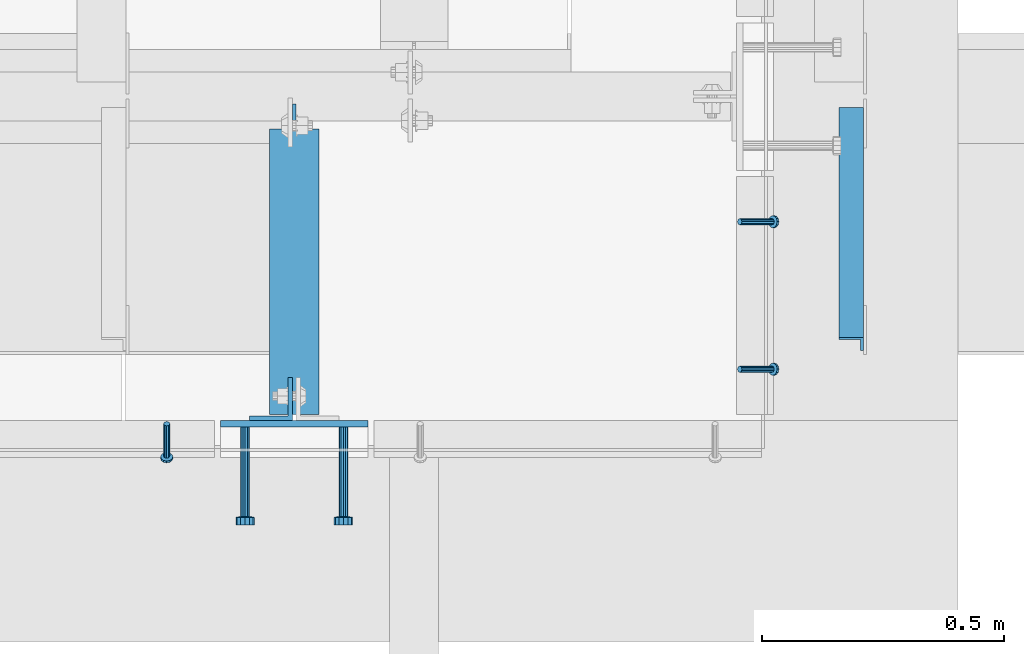
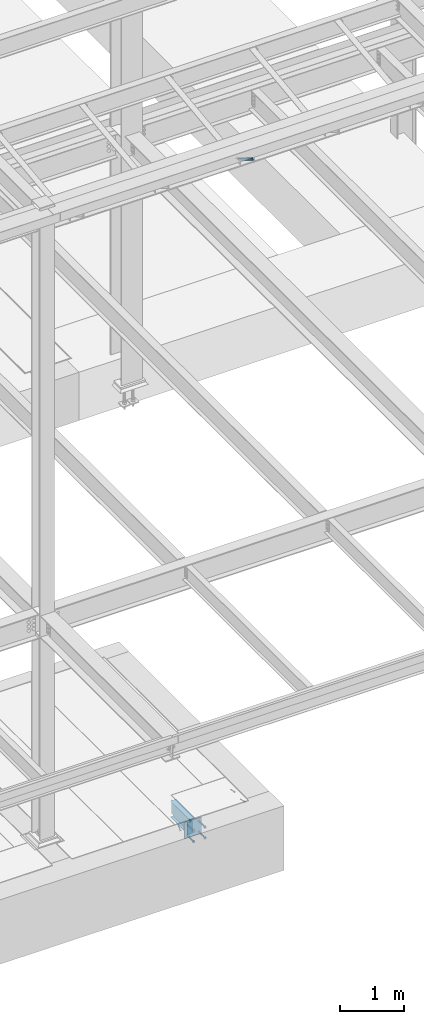
# One storey, part 2053 of 3843: 7 beams, 4 members, 5 elements without a shape of their own.
"""IFC2X3 building model written with IfcOpenShell, lengths in millimetres."""

import ifcopenshell
import ifcopenshell.guid

model = None  # the IFC model being written
_history = None  # IfcOwnerHistory: only IFC2X3 demands one
_inside = {}  # id of a spatial element -> (the spatial element, [elements in it])
_under = {}  # id of a project, library or spatial element -> (it, [spatial elements below it])
_declared = {}  # id of a project -> (the project, [libraries it declares])
_typed = {}  # id of a type object -> (the type object, [elements of that type])
_made_of = {}  # id of a material, layer set ... -> (it, [elements and type objects made of it])


def new_model(schema):
    """Start an empty IFC model of exactly this schema.

    Asked for "IFC4X3", IfcOpenShell would pick the latest addendum, in which some entities
    have other attributes; the version numbers below select the first issue.
    IFC2X3 requires an IfcOwnerHistory on every rooted entity: one is made here for all.
    """
    global model, _history
    if schema == "IFC4X3":
        model = ifcopenshell.file(schema_version=(4, 3, 0, 0))
    else:
        model = ifcopenshell.file(schema=schema)
    _inside.clear()
    _under.clear()
    _declared.clear()
    _typed.clear()
    _made_of.clear()
    _history = None
    if model.schema == "IFC2X3":
        org = make("IfcOrganization", Name="unknown")
        user = make(
            "IfcPersonAndOrganization",
            ThePerson=make("IfcPerson", FamilyName="unknown"),
            TheOrganization=org,
        )
        app = make(
            "IfcApplication",
            ApplicationDeveloper=org,
            Version="unknown",
            ApplicationFullName="unknown",
            ApplicationIdentifier="unknown",
        )
        _history = make(
            "IfcOwnerHistory",
            OwningUser=user,
            OwningApplication=app,
            ChangeAction="ADDED",
            CreationDate=0,
        )
    return model


def make(cls, **values):
    """One entity of the class cls with the attributes given. An attribute that is None is left unset."""
    return model.create_entity(
        cls, **{name: value for name, value in values.items() if value is not None}
    )


def rooted(cls, **values):
    """An entity with a GlobalId (a new one), such as an element, a storey or a relation."""
    return make(cls, GlobalId=ifcopenshell.guid.new(), OwnerHistory=_history, **values)


def si_unit(unit_type, name, prefix=None):
    """IfcSIUnit, for example si_unit("LENGTHUNIT", "METRE", prefix="MILLI")."""
    return make("IfcSIUnit", UnitType=unit_type, Prefix=prefix, Name=name)


def assignment(units):
    """IfcUnitAssignment: the units of a project."""
    return None if units is None else make("IfcUnitAssignment", Units=units)


def point(xyz):
    """IfcCartesianPoint."""
    return None if xyz is None else make("IfcCartesianPoint", Coordinates=xyz)


def direction(xyz):
    """IfcDirection."""
    return None if xyz is None else make("IfcDirection", DirectionRatios=xyz)


def frame(location, z_axis=None, x_axis=None):
    """IfcAxis2Placement3D, a coordinate frame: its origin and axes. An axis left out is left unset."""
    return make(
        "IfcAxis2Placement3D",
        Location=point(location),
        Axis=direction(z_axis),
        RefDirection=direction(x_axis),
    )


def origin_with_axes():
    """The frame at (0, 0, 0) with the z axis (0, 0, 1) and the x axis (1, 0, 0) written out."""
    return frame((0.0, 0.0, 0.0), z_axis=(0.0, 0.0, 1.0), x_axis=(1.0, 0.0, 0.0))


def place(relative_to, where):
    """IfcLocalPlacement: puts the frame where relative to a parent placement (None: the world)."""
    return make(
        "IfcLocalPlacement", PlacementRelTo=relative_to, RelativePlacement=where
    )


def context(
    kind, dimensions, precision=None, world=None, true_north=None, identifier=None
):
    """IfcGeometricRepresentationContext, for example the 3D "Model" context."""
    return make(
        "IfcGeometricRepresentationContext",
        ContextIdentifier=identifier,
        ContextType=kind,
        CoordinateSpaceDimension=dimensions,
        Precision=precision,
        WorldCoordinateSystem=world,
        TrueNorth=true_north,
    )


def subcontext(parent, identifier, kind, view, scale=None):
    """IfcGeometricRepresentationSubContext, for example "Body" below "Model"."""
    return make(
        "IfcGeometricRepresentationSubContext",
        ContextIdentifier=identifier,
        ContextType=kind,
        ParentContext=parent,
        TargetScale=scale,
        TargetView=view,
    )


def project(units=None, contexts=None):
    """IfcProject with its units and contexts."""
    return rooted(
        "IfcProject",
        Name="project",
        RepresentationContexts=contexts,
        UnitsInContext=assignment(units),
    )


def spatial(cls, under=None, at=None, **own):
    """A site, building, storey or space (cls), placed at a placement, below another one or the project."""
    s = rooted(cls, ObjectPlacement=at, **own)
    if under is not None:
        _under.setdefault(under.id(), (under, []))[1].append(s)
    return s


def faces_of(points, faces, orient=None, outer=None):
    """IfcFace entities. A face is a list of loops; a loop is a list of indices into points, from 0.

    orient and outer hold one flag for each loop. By default every Orientation is true, the
    first loop of a face is its IfcFaceOuterBound and the others are IfcFaceBound.
    """
    made = []
    for i, loops in enumerate(faces):
        bounds = []
        for j, loop in enumerate(loops):
            is_outer = j == 0 if outer is None else outer[i][j]
            bounds.append(
                make(
                    "IfcFaceOuterBound" if is_outer else "IfcFaceBound",
                    Bound=make("IfcPolyLoop", Polygon=[points[k] for k in loop]),
                    Orientation=True if orient is None else orient[i][j],
                )
            )
        made.append(make("IfcFace", Bounds=bounds))
    return made


def faceted_brep(points, faces, orient=None, outer=None, voids=None):
    """IfcFacetedBrep: a solid bounded by flat faces; with voids (closed shells), ...WithVoids."""
    shared = [point(p) for p in points]
    hull = make("IfcClosedShell", CfsFaces=faces_of(shared, faces, orient, outer))
    if voids is None:
        return make("IfcFacetedBrep", Outer=hull)
    return make(
        "IfcFacetedBrepWithVoids",
        Outer=hull,
        Voids=[
            make(cls, CfsFaces=faces_of(shared, fs, o, b)) for cls, fs, o, b in voids
        ],
    )


def shape(context_of_items, identifier, shape_type, items):
    """IfcShapeRepresentation: the items that make up one representation, for example the "Body"."""
    return make(
        "IfcShapeRepresentation",
        ContextOfItems=context_of_items,
        RepresentationIdentifier=identifier,
        RepresentationType=shape_type,
        Items=items,
    )


def material(Name=None, Category=None):
    """IfcMaterial."""
    return make("IfcMaterial", Name=Name, Category=Category)


def made_of(thing, what):
    """Note that an element or type object is made of a material, layer set ...; save() writes the relation."""
    if what is not None:
        _made_of.setdefault(what.id(), (what, []))[1].append(thing)
    return thing


def type_object(cls, material=None, **own):
    """A type object (cls), such as IfcWallType, which elements share."""
    return made_of(rooted(cls, **own), material)


def element(
    cls,
    number,
    at=None,
    inside=None,
    cuts=None,
    type_object=None,
    material=None,
    context=None,
    identifier="Body",
    shape_type=None,
    held_by="IfcProductDefinitionShape",
    body=None,
    shapes=None,
    **own,
):
    """One element of the class cls, such as IfcWall. Its Tag is "e" and its number.

    at: its placement. inside: the storey or other place that contains it. cuts: it is an
    opening in that element (IfcRelVoidsElement). A single representation is given by context,
    identifier, shape_type and body (its items); several are given by shapes. held_by: the class
    of the entity that holds the representations. save() writes the other relations.
    """
    e = rooted(cls, Tag="e%d" % number, ObjectPlacement=at, **own)
    if body is not None:
        shapes = [shape(context, identifier, shape_type, body)]
    if shapes is not None:
        e.Representation = make(held_by, Representations=shapes)
    if inside is not None:
        _inside.setdefault(inside.id(), (inside, []))[1].append(e)
    if cuts is not None:
        rooted(
            "IfcRelVoidsElement", RelatingBuildingElement=cuts, RelatedOpeningElement=e
        )
    if type_object is not None:
        _typed.setdefault(type_object.id(), (type_object, []))[1].append(e)
    return made_of(e, material)


def aggregate(whole, parts):
    """IfcRelAggregates: a whole, such as a stair, and the parts it consists of."""
    return rooted("IfcRelAggregates", RelatingObject=whole, RelatedObjects=parts)


def save(model, path):
    """Write the relations noted so far, then the file.

    IfcRelAggregates (storeys below a building ...), IfcRelContainedInSpatialStructure (elements
    in a storey), IfcRelDefinesByType, IfcRelAssociatesMaterial and IfcRelDeclares: one each for
    every whole, place, type object, material and project.
    """
    for whole, parts in _under.values():
        aggregate(whole, parts)
    for where, things in _inside.values():
        rooted(
            "IfcRelContainedInSpatialStructure",
            RelatedElements=things,
            RelatingStructure=where,
        )
    for kind, things in _typed.values():
        rooted("IfcRelDefinesByType", RelatedObjects=things, RelatingType=kind)
    for what, things in _made_of.values():
        rooted("IfcRelAssociatesMaterial", RelatedObjects=things, RelatingMaterial=what)
    for by, libraries in _declared.values():
        rooted("IfcRelDeclares", RelatingContext=by, RelatedDefinitions=libraries)
    model.write(path)


model = new_model("IFC2X3")

# Units and contexts
model_context = context("Model", 3, precision=1e-05, world=origin_with_axes())
body_context = subcontext(model_context, "Body", "Model", "MODEL_VIEW")
ifc_project = project(units=[si_unit("LENGTHUNIT", "METRE", prefix="MILLI"), si_unit("AREAUNIT", "SQUARE_METRE"), si_unit("VOLUMEUNIT", "CUBIC_METRE"), si_unit("MASSUNIT", "GRAM", prefix="KILO"), si_unit("TIMEUNIT", "SECOND"), si_unit("PLANEANGLEUNIT", "RADIAN"), si_unit("SOLIDANGLEUNIT", "STERADIAN"), si_unit("THERMODYNAMICTEMPERATUREUNIT", "DEGREE_CELSIUS"), si_unit("LUMINOUSINTENSITYUNIT", "LUMEN")], contexts=[model_context])

# Site, building, storey
site_placement = place(None, origin_with_axes())
site = spatial("IfcSite", under=ifc_project, at=site_placement, CompositionType="ELEMENT")
building_placement = place(site_placement, origin_with_axes())
building = spatial("IfcBuilding", under=site, at=building_placement, Name="Undefined", CompositionType="ELEMENT")
storey_placement = place(building_placement, origin_with_axes())
storey = spatial("IfcBuildingStorey", under=building, at=storey_placement, Name="Undefined", CompositionType="ELEMENT", Elevation=0.0)

# Assembly, members
assembly_1_placement = place(storey_placement, origin_with_axes())
assembly_1 = element("IfcElementAssembly", 1, at=assembly_1_placement, inside=storey, Name="ANGLE", AssemblyPlace="NOTDEFINED", PredefinedType="RIGID_FRAME")
ifc_material_1 = material(Name="STEEL/A108")
member_type_1 = type_object("IfcMemberType", PredefinedType="NOTDEFINED")
member_1_placement = place(assembly_1_placement, frame((65849.5000291437, 14739.9375896267, 30422.8500045777), z_axis=(0.0, 1.0, 0.0), x_axis=(0.707106781186548, 0.0, -0.707106781186548)))
member_1 = element("IfcMember", 2, at=member_1_placement, type_object=member_type_1, material=ifc_material_1, Name="HEADED STUD ANCHOR", context=body_context, shape_type="Brep", body=[
    faceted_brep([(7.27595761418343e-12, -3.18000006675175, 5.5), (0.0, -5.49999999998363, 3.1800000667572), (94.4879985803855, -5.50000000011278, 3.1800000667572), (94.4879985803782, -3.18000006687362, 5.5), (0.0, -6.3499999046162, 0.0), (94.4879985803855, -6.34999990474535, 0.0), (0.0, -5.49999999998363, -3.1800000667572), (94.4879985803855, -5.50000000011278, -3.1800000667572), (7.27595761418343e-12, -3.18000006675175, -5.5), (94.4879985803782, -3.18000006687362, -5.5), (7.27595761418343e-12, -1.81898940354586e-12, -6.34999990463257), (94.4879985803782, -1.20053300634027e-10, -6.34999990463257), (0.0, 3.18000006675175, -5.5), (94.4879985803709, 3.18000006663351, -5.5), (7.27595761418343e-12, 5.49999999998363, -3.1800000667572), (94.4879985803709, 5.49999999987267, -3.1800000667572), (7.27595761418343e-12, 6.3499999046162, 0.0), (94.4879985803673, 6.34999990450706, 0.0), (7.27595761418343e-12, 5.49999999998363, 3.1800000667572), (94.4879985803709, 5.49999999987267, 3.1800000667572), (0.0, 3.18000006675175, 5.5), (94.4879985803709, 3.18000006663351, 5.5), (7.27595761418343e-12, -1.81898940354586e-12, 6.34999990463257), (94.4879985803782, -1.20053300634027e-10, 6.34999990463257), (96.5199985498621, -10.9899997712273, 6.34999990463257), (96.5199985498548, -6.34000015270249, 10.9899997711182), (96.5199985498621, -12.6999998093743, 0.0), (96.5199985498621, -10.9899997712273, -6.34999990463257), (96.5199985498548, -6.34000015270249, -10.9899997711182), (96.5199985498475, -1.21872290037572e-10, -12.6899995803833), (96.5199985498402, 6.34000015245874, -10.9899997711182), (96.519998549833, 10.9899997709817, -6.34999990463257), (96.519998549833, 12.6999998091305, 0.0), (96.519998549833, 10.9899997709817, 6.34999990463257), (96.5199985498402, 6.34000015245874, 10.9899997711182), (96.5199985498475, -1.21872290037572e-10, 12.6899995803833), (101.599998473539, -10.9899997712328, 6.34999990463257), (101.599998473532, -6.34000015270976, 10.9899997711182), (101.599998473539, -12.6999998093797, 0.0), (101.599998473539, -10.9899997712328, -6.34999990463257), (101.599998473532, -6.34000015270976, -10.9899997711182), (101.599998473524, -1.29148247651756e-10, -12.6899995803833), (101.599998473517, 6.34000015245329, -10.9899997711182), (101.59999847351, 10.9899997709763, -6.34999990463257), (101.599998473503, 12.6999998091196, 0.0), (101.59999847351, 10.9899997709763, 6.34999990463257), (101.599998473517, 6.34000015245329, 10.9899997711182), (101.599998473524, -1.29148247651756e-10, 12.6899995803833)], [[[0, 1, 2, 3]], [[1, 4, 5, 2]], [[4, 6, 7, 5]], [[6, 8, 9, 7]], [[8, 10, 11, 9]], [[10, 12, 13, 11]], [[12, 14, 15, 13]], [[14, 16, 17, 15]], [[16, 18, 19, 17]], [[18, 20, 21, 19]], [[20, 22, 23, 21]], [[22, 0, 3, 23]], [[22, 20, 18, 16, 14, 12, 10, 8, 6, 4, 1, 0]], [[3, 2, 24, 25]], [[2, 5, 26, 24]], [[5, 7, 27, 26]], [[7, 9, 28, 27]], [[9, 11, 29, 28]], [[11, 13, 30, 29]], [[13, 15, 31, 30]], [[15, 17, 32, 31]], [[17, 19, 33, 32]], [[19, 21, 34, 33]], [[21, 23, 35, 34]], [[23, 3, 25, 35]], [[25, 24, 36, 37]], [[24, 26, 38, 36]], [[26, 27, 39, 38]], [[27, 28, 40, 39]], [[28, 29, 41, 40]], [[29, 30, 42, 41]], [[30, 31, 43, 42]], [[31, 32, 44, 43]], [[32, 33, 45, 44]], [[33, 34, 46, 45]], [[34, 35, 47, 46]], [[35, 25, 37, 47]], [[38, 39, 40, 41, 42, 43, 44, 45, 46, 47, 37, 36]]]),
])
member_2_placement = place(assembly_1_placement, frame((65849.5000291437, 14435.1375896267, 30422.8500045777), z_axis=(0.0, 1.0, 0.0), x_axis=(0.707106781186548, 0.0, -0.707106781186548)))
member_2 = element("IfcMember", 3, at=member_2_placement, type_object=member_type_1, material=ifc_material_1, Name="HEADED STUD ANCHOR", context=body_context, shape_type="Brep", body=[
    faceted_brep([(7.27595761418343e-12, -3.18000006675175, 5.5), (0.0, -5.49999999998363, 3.1800000667572), (94.4879985803855, -5.50000000011278, 3.1800000667572), (94.4879985803782, -3.18000006687362, 5.5), (0.0, -6.3499999046162, 0.0), (94.4879985803855, -6.34999990474535, 0.0), (0.0, -5.49999999998363, -3.1800000667572), (94.4879985803855, -5.50000000011278, -3.1800000667572), (7.27595761418343e-12, -3.18000006675175, -5.5), (94.4879985803782, -3.18000006687362, -5.5), (7.27595761418343e-12, -1.81898940354586e-12, -6.34999990463257), (94.4879985803782, -1.20053300634027e-10, -6.34999990463257), (0.0, 3.18000006675175, -5.5), (94.4879985803709, 3.18000006663351, -5.5), (7.27595761418343e-12, 5.49999999998363, -3.1800000667572), (94.4879985803709, 5.49999999987267, -3.1800000667572), (7.27595761418343e-12, 6.3499999046162, 0.0), (94.4879985803673, 6.34999990450706, 0.0), (7.27595761418343e-12, 5.49999999998363, 3.1800000667572), (94.4879985803709, 5.49999999987267, 3.1800000667572), (0.0, 3.18000006675175, 5.5), (94.4879985803709, 3.18000006663351, 5.5), (7.27595761418343e-12, -1.81898940354586e-12, 6.34999990463257), (94.4879985803782, -1.20053300634027e-10, 6.34999990463257), (96.5199985498621, -10.9899997712273, 6.34999990463257), (96.5199985498548, -6.34000015270249, 10.9899997711182), (96.5199985498621, -12.6999998093743, 0.0), (96.5199985498621, -10.9899997712273, -6.34999990463257), (96.5199985498548, -6.34000015270249, -10.9899997711182), (96.5199985498475, -1.21872290037572e-10, -12.6899995803833), (96.5199985498402, 6.34000015245874, -10.9899997711182), (96.519998549833, 10.9899997709817, -6.34999990463257), (96.519998549833, 12.6999998091305, 0.0), (96.519998549833, 10.9899997709817, 6.34999990463257), (96.5199985498402, 6.34000015245874, 10.9899997711182), (96.5199985498475, -1.21872290037572e-10, 12.6899995803833), (101.599998473539, -10.9899997712328, 6.34999990463257), (101.599998473532, -6.34000015270976, 10.9899997711182), (101.599998473539, -12.6999998093797, 0.0), (101.599998473539, -10.9899997712328, -6.34999990463257), (101.599998473532, -6.34000015270976, -10.9899997711182), (101.599998473524, -1.29148247651756e-10, -12.6899995803833), (101.599998473517, 6.34000015245329, -10.9899997711182), (101.59999847351, 10.9899997709763, -6.34999990463257), (101.599998473503, 12.6999998091196, 0.0), (101.59999847351, 10.9899997709763, 6.34999990463257), (101.599998473517, 6.34000015245329, 10.9899997711182), (101.599998473524, -1.29148247651756e-10, 12.6899995803833)], [[[0, 1, 2, 3]], [[1, 4, 5, 2]], [[4, 6, 7, 5]], [[6, 8, 9, 7]], [[8, 10, 11, 9]], [[10, 12, 13, 11]], [[12, 14, 15, 13]], [[14, 16, 17, 15]], [[16, 18, 19, 17]], [[18, 20, 21, 19]], [[20, 22, 23, 21]], [[22, 0, 3, 23]], [[22, 20, 18, 16, 14, 12, 10, 8, 6, 4, 1, 0]], [[3, 2, 24, 25]], [[2, 5, 26, 24]], [[5, 7, 27, 26]], [[7, 9, 28, 27]], [[9, 11, 29, 28]], [[11, 13, 30, 29]], [[13, 15, 31, 30]], [[15, 17, 32, 31]], [[17, 19, 33, 32]], [[19, 21, 34, 33]], [[21, 23, 35, 34]], [[23, 3, 25, 35]], [[25, 24, 36, 37]], [[24, 26, 38, 36]], [[26, 27, 39, 38]], [[27, 28, 40, 39]], [[28, 29, 41, 40]], [[29, 30, 42, 41]], [[30, 31, 43, 42]], [[31, 32, 44, 43]], [[32, 33, 45, 44]], [[33, 34, 46, 45]], [[34, 35, 47, 46]], [[35, 25, 37, 47]], [[38, 39, 40, 41, 42, 43, 44, 45, 46, 47, 37, 36]]]),
])
aggregate(assembly_1, [member_1, member_2])

# Assembly, member
assembly_2_placement = place(storey_placement, origin_with_axes())
assembly_2 = element("IfcElementAssembly", 4, at=assembly_2_placement, inside=storey, Name="ANGLE", AssemblyPlace="NOTDEFINED", PredefinedType="RIGID_FRAME")
member_3_placement = place(assembly_2_placement, frame((64665.2249989808, 14322.4249538032, 30422.8500024177), z_axis=(1.0, 0.0, 0.0), x_axis=(0.0, -0.707106781186548, -0.707106781186548)))
member_3 = element("IfcMember", 5, at=member_3_placement, type_object=member_type_1, material=ifc_material_1, Name="HEADED STUD ANCHOR", context=body_context, shape_type="Brep", body=[
    faceted_brep([(7.27595761418343e-12, -3.18000006675175, 5.5), (0.0, -5.49999999998363, 3.1800000667572), (94.4879985803855, -5.50000000011278, 3.1800000667572), (94.4879985803782, -3.18000006687362, 5.5), (0.0, -6.3499999046162, 0.0), (94.4879985803855, -6.34999990474535, 0.0), (0.0, -5.49999999998363, -3.1800000667572), (94.4879985803855, -5.50000000011278, -3.1800000667572), (7.27595761418343e-12, -3.18000006675175, -5.5), (94.4879985803782, -3.18000006687362, -5.5), (7.27595761418343e-12, -1.81898940354586e-12, -6.34999990463257), (94.4879985803782, -1.20053300634027e-10, -6.34999990463257), (0.0, 3.18000006675175, -5.5), (94.4879985803709, 3.18000006663351, -5.5), (7.27595761418343e-12, 5.49999999998363, -3.1800000667572), (94.4879985803709, 5.49999999987267, -3.1800000667572), (7.27595761418343e-12, 6.3499999046162, 0.0), (94.4879985803673, 6.34999990450706, 0.0), (7.27595761418343e-12, 5.49999999998363, 3.1800000667572), (94.4879985803709, 5.49999999987267, 3.1800000667572), (0.0, 3.18000006675175, 5.5), (94.4879985803709, 3.18000006663351, 5.5), (7.27595761418343e-12, -1.81898940354586e-12, 6.34999990463257), (94.4879985803782, -1.20053300634027e-10, 6.34999990463257), (96.5199985498621, -10.9899997712273, 6.34999990463257), (96.5199985498548, -6.34000015270249, 10.9899997711182), (96.5199985498621, -12.6999998093743, 0.0), (96.5199985498621, -10.9899997712273, -6.34999990463257), (96.5199985498548, -6.34000015270249, -10.9899997711182), (96.5199985498475, -1.21872290037572e-10, -12.6899995803833), (96.5199985498402, 6.34000015245874, -10.9899997711182), (96.519998549833, 10.9899997709817, -6.34999990463257), (96.519998549833, 12.6999998091305, 0.0), (96.519998549833, 10.9899997709817, 6.34999990463257), (96.5199985498402, 6.34000015245874, 10.9899997711182), (96.5199985498475, -1.21872290037572e-10, 12.6899995803833), (101.599998473539, -10.9899997712328, 6.34999990463257), (101.599998473532, -6.34000015270976, 10.9899997711182), (101.599998473539, -12.6999998093797, 0.0), (101.599998473539, -10.9899997712328, -6.34999990463257), (101.599998473532, -6.34000015270976, -10.9899997711182), (101.599998473524, -1.29148247651756e-10, -12.6899995803833), (101.599998473517, 6.34000015245329, -10.9899997711182), (101.59999847351, 10.9899997709763, -6.34999990463257), (101.599998473503, 12.6999998091196, 0.0), (101.59999847351, 10.9899997709763, 6.34999990463257), (101.599998473517, 6.34000015245329, 10.9899997711182), (101.599998473524, -1.29148247651756e-10, 12.6899995803833)], [[[0, 1, 2, 3]], [[1, 4, 5, 2]], [[4, 6, 7, 5]], [[6, 8, 9, 7]], [[8, 10, 11, 9]], [[10, 12, 13, 11]], [[12, 14, 15, 13]], [[14, 16, 17, 15]], [[16, 18, 19, 17]], [[18, 20, 21, 19]], [[20, 22, 23, 21]], [[22, 0, 3, 23]], [[22, 20, 18, 16, 14, 12, 10, 8, 6, 4, 1, 0]], [[3, 2, 24, 25]], [[2, 5, 26, 24]], [[5, 7, 27, 26]], [[7, 9, 28, 27]], [[9, 11, 29, 28]], [[11, 13, 30, 29]], [[13, 15, 31, 30]], [[15, 17, 32, 31]], [[17, 19, 33, 32]], [[19, 21, 34, 33]], [[21, 23, 35, 34]], [[23, 3, 25, 35]], [[25, 24, 36, 37]], [[24, 26, 38, 36]], [[26, 27, 39, 38]], [[27, 28, 40, 39]], [[28, 29, 41, 40]], [[29, 30, 42, 41]], [[30, 31, 43, 42]], [[31, 32, 44, 43]], [[32, 33, 45, 44]], [[33, 34, 46, 45]], [[34, 35, 47, 46]], [[35, 25, 37, 47]], [[38, 39, 40, 41, 42, 43, 44, 45, 46, 47, 37, 36]]]),
])
aggregate(assembly_2, [member_3])

# Assembly, beam
assembly_3_placement = place(storey_placement, origin_with_axes())
assembly_3 = element("IfcElementAssembly", 6, at=assembly_3_placement, inside=storey, Name="EMBED PLATE", AssemblyPlace="NOTDEFINED", PredefinedType="RIGID_FRAME")
ifc_material_2 = material(Name="STEEL/A36")
beam_type_1 = type_object("IfcBeamType", PredefinedType="NOTDEFINED")
beam_1_placement = place(assembly_3_placement, frame((64928.75, 14322.4250030517, 30422.85), z_axis=(-1.0, 0.0, 0.0), x_axis=(0.0, 0.0, -1.0)))
beam_1 = element("IfcBeam", 7, at=beam_1_placement, type_object=beam_type_1, material=ifc_material_2, Name="EMBED PLATE", context=body_context, shape_type="Brep", body=[
    faceted_brep([(-1.0550138540566e-10, 6.34999999999854, -152.400000000664), (1.0550138540566e-10, 6.34999999999854, 152.400000000656), (304.799999999999, 6.34999999999854, 152.400000000001), (304.799999999999, 6.34999999999854, -152.400000000001), (1.0550138540566e-10, -6.34999999999854, 152.400000000656), (304.799999999999, -6.34999999999854, 152.400000000001), (-1.0550138540566e-10, -6.34999999999854, -152.400000000664), (304.799999999999, -6.34999999999854, -152.400000000001)], [[[0, 1, 2, 3]], [[1, 4, 5, 2]], [[4, 6, 7, 5]], [[6, 0, 3, 7]], [[5, 7, 3, 2]], [[6, 4, 1, 0]]]),
])

# Assembly, member
assembly_4_placement = place(storey_placement, origin_with_axes())
assembly_4 = element("IfcElementAssembly", 8, at=assembly_4_placement, inside=storey, Name="ANGLE", AssemblyPlace="NOTDEFINED", PredefinedType="RIGID_FRAME")
ifc_material_3 = material(Name="STEEL/A572-50")
member_type_2 = type_object("IfcMemberType", Name="L2X2X1/4", PredefinedType="NOTDEFINED")
member_4_placement = place(assembly_4_placement, frame((66079.6875, 14962.4615149769, 42136.6100587905), z_axis=(-1.0, 0.0, 0.0), x_axis=(0.0, -0.851012521472712, 0.5251453972917)))
member_4 = element("IfcMember", 9, at=member_4_placement, type_object=member_type_2, material=ifc_material_3, Name="ANGLE", ObjectType="L2X2X1/4", context=body_context, shape_type="Brep", body=[
    faceted_brep([(0.0, 25.4000000000015, -25.4000000000015), (0.0, 25.4000000000015, 25.4000000000015), (558.799999999297, 25.3999999986918, 25.3999999999942), (558.799999999297, 25.3999999986918, -25.3999999999942), (0.0, 19.0500000000029, 25.4000000000015), (558.799999999297, 19.049999998686, 25.3999999999942), (0.0, 19.0500000000029, -19.0499999999993), (558.799999999297, 19.049999998686, -19.0500000000029), (0.0, -25.4000000000015, -19.0499999999993), (558.799999999281, -25.4000000013912, -19.0500000000029), (0.0, -25.4000000000015, -25.4000000000015), (558.799999999281, -25.4000000013912, -25.3999999999942)], [[[0, 1, 2, 3]], [[1, 4, 5, 2]], [[4, 6, 7, 5]], [[6, 8, 9, 7]], [[8, 10, 11, 9]], [[10, 0, 3, 11]], [[5, 7, 9, 11, 3, 2]], [[10, 8, 6, 4, 1, 0]]]),
])
aggregate(assembly_4, [member_4])

# Assembly, beam
assembly_5_placement = place(storey_placement, origin_with_axes())
assembly_5 = element("IfcElementAssembly", 10, at=assembly_5_placement, inside=storey, Name="BEAM", AssemblyPlace="NOTDEFINED", PredefinedType="RIGID_FRAME")
beam_type_2 = type_object("IfcBeamType", Name="L3-1/2X3-1/2X3/8", PredefinedType="NOTDEFINED")
beam_2_placement = place(assembly_5_placement, frame((64881.125, 14373.2250030517, 30391.1), z_axis=(-1.0, 0.0, 0.0), x_axis=(0.0, 0.0, -1.0)))
beam_2 = element("IfcBeam", 11, at=beam_2_placement, type_object=beam_type_2, material=ifc_material_2, Name="ANGLE", ObjectType="L3-1/2X3-1/2X3/8", context=body_context, shape_type="Brep", body=[
    faceted_brep([(-3.63797880709171e-12, 44.4499999999971, -44.4500000000007), (-3.63797880709171e-12, 44.4499999999971, 44.4500000000007), (228.600000000006, 44.4499999999971, 44.4500000000007), (228.600000000006, 44.4499999999971, -44.4500000000007), (0.0, 34.9250000000029, 44.4500000000007), (228.600000000006, 34.9250000000029, 44.4500000000007), (0.0, 34.9250000000029, -34.9250000000029), (228.600000000006, 34.9250000000029, -34.9249999999993), (0.0, -44.4499999999971, -34.9249999999993), (228.600000000006, -44.4499999999971, -34.9249999999993), (3.63797880709171e-12, -44.4499999999971, -44.4500000000007), (228.600000000006, -44.4499999999971, -44.4500000000007)], [[[0, 1, 2, 3]], [[1, 4, 5, 2]], [[4, 6, 7, 5]], [[6, 8, 9, 7]], [[8, 10, 11, 9]], [[10, 0, 3, 11]], [[5, 7, 9, 11, 3, 2]], [[10, 8, 6, 4, 1, 0]]]),
])

# Beam
beam_type_3 = type_object("IfcBeamType", PredefinedType="NOTDEFINED")
beam_3_placement = place(assembly_3_placement, frame((65030.35, 14316.0750030517, 30372.05), z_axis=(1.0, 0.0, 0.0), x_axis=(0.0, -1.0, 0.0)))
beam_3 = element("IfcBeam", 12, at=beam_3_placement, type_object=beam_type_3, material=ifc_material_1, Name="HEADED STUD ANCHOR", context=body_context, shape_type="Brep", body=[
    faceted_brep([(0.0, -9.52000045776367, 0.0), (0.0, -8.25, -4.76000022888184), (184.912000000004, -8.25, -4.76000022888184), (184.912000000004, -9.52000045776367, 0.0), (0.0, -4.76000022888184, -8.25), (184.912000000004, -4.76000022888184, -8.25), (0.0, 0.0, -9.52000045776367), (184.912000000004, 0.0, -9.52000045776367), (0.0, 4.76000022888184, -8.25), (184.912000000004, 4.76000022888184, -8.25), (0.0, 8.25, -4.76000022888184), (184.912000000004, 8.25, -4.76000022888184), (0.0, 9.52000045776367, 0.0), (184.912000000004, 9.52000045776367, 0.0), (0.0, 8.25, 4.76000022888184), (184.912000000004, 8.25, 4.76000022888184), (0.0, 4.76000022888184, 8.25), (184.912000000004, 4.76000022888184, 8.25), (0.0, 0.0, 9.52000045776367), (184.912000000004, 0.0, 9.52000045776367), (0.0, -4.76000022888184, 8.25), (184.912000000004, -4.76000022888184, 8.25), (0.0, -8.25, 4.76000022888184), (184.912000000004, -8.25, 4.76000022888184), (186.944000000003, -16.5, -9.52000045776367), (186.944000000003, -19.0499992370605, 0.0), (186.944000000003, -9.52000045776367, -16.5), (186.944000000003, 0.0, -19.0499992370605), (186.944000000003, 9.52000045776367, -16.5), (186.944000000003, 16.5, -9.52000045776367), (186.944000000003, 19.0499992370605, 0.0), (186.944000000003, 16.5, 9.52000045776367), (186.944000000003, 9.52000045776367, 16.5), (186.944000000003, 0.0, 19.0499992370605), (186.944000000003, -9.52000045776367, 16.5), (186.944000000003, -16.5, 9.52000045776367), (203.199999999997, -16.5, -9.52000045776367), (203.199999999997, -19.0499992370605, 0.0), (203.199999999997, -9.52000045776367, -16.5), (203.199999999997, 0.0, -19.0499992370605), (203.199999999997, 9.52000045776367, -16.5), (203.199999999997, 16.5, -9.52000045776367), (203.199999999997, 19.0499992370605, 0.0), (203.199999999997, 16.5, 9.52000045776367), (203.199999999997, 9.52000045776367, 16.5), (203.199999999997, 0.0, 19.0499992370605), (203.199999999997, -9.52000045776367, 16.5), (203.199999999997, -16.5, 9.52000045776367)], [[[0, 1, 2, 3]], [[1, 4, 5, 2]], [[4, 6, 7, 5]], [[6, 8, 9, 7]], [[8, 10, 11, 9]], [[10, 12, 13, 11]], [[12, 14, 15, 13]], [[14, 16, 17, 15]], [[16, 18, 19, 17]], [[18, 20, 21, 19]], [[20, 22, 23, 21]], [[22, 0, 3, 23]], [[22, 20, 18, 16, 14, 12, 10, 8, 6, 4, 1, 0]], [[3, 2, 24, 25]], [[2, 5, 26, 24]], [[5, 7, 27, 26]], [[7, 9, 28, 27]], [[9, 11, 29, 28]], [[11, 13, 30, 29]], [[13, 15, 31, 30]], [[15, 17, 32, 31]], [[17, 19, 33, 32]], [[19, 21, 34, 33]], [[21, 23, 35, 34]], [[23, 3, 25, 35]], [[25, 24, 36, 37]], [[24, 26, 38, 36]], [[26, 27, 39, 38]], [[27, 28, 40, 39]], [[28, 29, 41, 40]], [[29, 30, 42, 41]], [[30, 31, 43, 42]], [[31, 32, 44, 43]], [[32, 33, 45, 44]], [[33, 34, 46, 45]], [[34, 35, 47, 46]], [[35, 25, 37, 47]], [[38, 39, 40, 41, 42, 43, 44, 45, 46, 47, 37, 36]]]),
])

beam_4_placement = place(assembly_3_placement, frame((65030.35, 14316.0750030517, 30168.85), z_axis=(1.0, 0.0, 0.0), x_axis=(0.0, -1.0, 0.0)))
beam_4 = element("IfcBeam", 13, at=beam_4_placement, type_object=beam_type_3, material=ifc_material_1, Name="HEADED STUD ANCHOR", context=body_context, shape_type="Brep", body=[
    faceted_brep([(0.0, -9.52000045776367, 0.0), (0.0, -8.25, -4.76000022888184), (184.912000000004, -8.25, -4.76000022888184), (184.912000000004, -9.52000045776367, 0.0), (0.0, -4.76000022888184, -8.25), (184.912000000004, -4.76000022888184, -8.25), (0.0, 0.0, -9.52000045776367), (184.912000000004, 0.0, -9.52000045776367), (0.0, 4.76000022888184, -8.25), (184.912000000004, 4.76000022888184, -8.25), (0.0, 8.25, -4.76000022888184), (184.912000000004, 8.25, -4.76000022888184), (0.0, 9.52000045776367, 0.0), (184.912000000004, 9.52000045776367, 0.0), (0.0, 8.25, 4.76000022888184), (184.912000000004, 8.25, 4.76000022888184), (0.0, 4.76000022888184, 8.25), (184.912000000004, 4.76000022888184, 8.25), (0.0, 0.0, 9.52000045776367), (184.912000000004, 0.0, 9.52000045776367), (0.0, -4.76000022888184, 8.25), (184.912000000004, -4.76000022888184, 8.25), (0.0, -8.25, 4.76000022888184), (184.912000000004, -8.25, 4.76000022888184), (186.944000000003, -16.5, -9.52000045776367), (186.944000000003, -19.0499992370605, 0.0), (186.944000000003, -9.52000045776367, -16.5), (186.944000000003, 0.0, -19.0499992370605), (186.944000000003, 9.52000045776367, -16.5), (186.944000000003, 16.5, -9.52000045776367), (186.944000000003, 19.0499992370605, 0.0), (186.944000000003, 16.5, 9.52000045776367), (186.944000000003, 9.52000045776367, 16.5), (186.944000000003, 0.0, 19.0499992370605), (186.944000000003, -9.52000045776367, 16.5), (186.944000000003, -16.5, 9.52000045776367), (203.199999999997, -16.5, -9.52000045776367), (203.199999999997, -19.0499992370605, 0.0), (203.199999999997, -9.52000045776367, -16.5), (203.199999999997, 0.0, -19.0499992370605), (203.199999999997, 9.52000045776367, -16.5), (203.199999999997, 16.5, -9.52000045776367), (203.199999999997, 19.0499992370605, 0.0), (203.199999999997, 16.5, 9.52000045776367), (203.199999999997, 9.52000045776367, 16.5), (203.199999999997, 0.0, 19.0499992370605), (203.199999999997, -9.52000045776367, 16.5), (203.199999999997, -16.5, 9.52000045776367)], [[[0, 1, 2, 3]], [[1, 4, 5, 2]], [[4, 6, 7, 5]], [[6, 8, 9, 7]], [[8, 10, 11, 9]], [[10, 12, 13, 11]], [[12, 14, 15, 13]], [[14, 16, 17, 15]], [[16, 18, 19, 17]], [[18, 20, 21, 19]], [[20, 22, 23, 21]], [[22, 0, 3, 23]], [[22, 20, 18, 16, 14, 12, 10, 8, 6, 4, 1, 0]], [[3, 2, 24, 25]], [[2, 5, 26, 24]], [[5, 7, 27, 26]], [[7, 9, 28, 27]], [[9, 11, 29, 28]], [[11, 13, 30, 29]], [[13, 15, 31, 30]], [[15, 17, 32, 31]], [[17, 19, 33, 32]], [[19, 21, 34, 33]], [[21, 23, 35, 34]], [[23, 3, 25, 35]], [[25, 24, 36, 37]], [[24, 26, 38, 36]], [[26, 27, 39, 38]], [[27, 28, 40, 39]], [[28, 29, 41, 40]], [[29, 30, 42, 41]], [[30, 31, 43, 42]], [[31, 32, 44, 43]], [[32, 33, 45, 44]], [[33, 34, 46, 45]], [[34, 35, 47, 46]], [[35, 25, 37, 47]], [[38, 39, 40, 41, 42, 43, 44, 45, 46, 47, 37, 36]]]),
])

beam_5_placement = place(assembly_3_placement, frame((64827.15, 14316.0750030517, 30372.05), z_axis=(1.0, 0.0, 0.0), x_axis=(0.0, -1.0, 0.0)))
beam_5 = element("IfcBeam", 14, at=beam_5_placement, type_object=beam_type_3, material=ifc_material_2, Name="PLATE", context=body_context, shape_type="Brep", body=[
    faceted_brep([(0.0, -9.52000045776367, 0.0), (0.0, -8.25, -4.76000022888184), (184.912000000004, -8.25, -4.76000022888184), (184.912000000004, -9.52000045776367, 0.0), (0.0, -4.76000022888184, -8.25), (184.912000000004, -4.76000022888184, -8.25), (0.0, 0.0, -9.52000045776367), (184.912000000004, 0.0, -9.52000045776367), (0.0, 4.76000022888184, -8.25), (184.912000000004, 4.76000022888184, -8.25), (0.0, 8.25, -4.76000022888184), (184.912000000004, 8.25, -4.76000022888184), (0.0, 9.52000045776367, 0.0), (184.912000000004, 9.52000045776367, 0.0), (0.0, 8.25, 4.76000022888184), (184.912000000004, 8.25, 4.76000022888184), (0.0, 4.76000022888184, 8.25), (184.912000000004, 4.76000022888184, 8.25), (0.0, 0.0, 9.52000045776367), (184.912000000004, 0.0, 9.52000045776367), (0.0, -4.76000022888184, 8.25), (184.912000000004, -4.76000022888184, 8.25), (0.0, -8.25, 4.76000022888184), (184.912000000004, -8.25, 4.76000022888184), (186.944000000003, -16.5, -9.52000045776367), (186.944000000003, -19.0499992370605, 0.0), (186.944000000003, -9.52000045776367, -16.5), (186.944000000003, 0.0, -19.0499992370605), (186.944000000003, 9.52000045776367, -16.5), (186.944000000003, 16.5, -9.52000045776367), (186.944000000003, 19.0499992370605, 0.0), (186.944000000003, 16.5, 9.52000045776367), (186.944000000003, 9.52000045776367, 16.5), (186.944000000003, 0.0, 19.0499992370605), (186.944000000003, -9.52000045776367, 16.5), (186.944000000003, -16.5, 9.52000045776367), (203.199999999997, -16.5, -9.52000045776367), (203.199999999997, -19.0499992370605, 0.0), (203.199999999997, -9.52000045776367, -16.5), (203.199999999997, 0.0, -19.0499992370605), (203.199999999997, 9.52000045776367, -16.5), (203.199999999997, 16.5, -9.52000045776367), (203.199999999997, 19.0499992370605, 0.0), (203.199999999997, 16.5, 9.52000045776367), (203.199999999997, 9.52000045776367, 16.5), (203.199999999997, 0.0, 19.0499992370605), (203.199999999997, -9.52000045776367, 16.5), (203.199999999997, -16.5, 9.52000045776367)], [[[0, 1, 2, 3]], [[1, 4, 5, 2]], [[4, 6, 7, 5]], [[6, 8, 9, 7]], [[8, 10, 11, 9]], [[10, 12, 13, 11]], [[12, 14, 15, 13]], [[14, 16, 17, 15]], [[16, 18, 19, 17]], [[18, 20, 21, 19]], [[20, 22, 23, 21]], [[22, 0, 3, 23]], [[22, 20, 18, 16, 14, 12, 10, 8, 6, 4, 1, 0]], [[3, 2, 24, 25]], [[2, 5, 26, 24]], [[5, 7, 27, 26]], [[7, 9, 28, 27]], [[9, 11, 29, 28]], [[11, 13, 30, 29]], [[13, 15, 31, 30]], [[15, 17, 32, 31]], [[17, 19, 33, 32]], [[19, 21, 34, 33]], [[21, 23, 35, 34]], [[23, 3, 25, 35]], [[25, 24, 36, 37]], [[24, 26, 38, 36]], [[26, 27, 39, 38]], [[27, 28, 40, 39]], [[28, 29, 41, 40]], [[29, 30, 42, 41]], [[30, 31, 43, 42]], [[31, 32, 44, 43]], [[32, 33, 45, 44]], [[33, 34, 46, 45]], [[34, 35, 47, 46]], [[35, 25, 37, 47]], [[38, 39, 40, 41, 42, 43, 44, 45, 46, 47, 37, 36]]]),
])

beam_6_placement = place(assembly_3_placement, frame((64827.15, 14316.0750030517, 30168.85), z_axis=(1.0, 0.0, 0.0), x_axis=(0.0, -1.0, 0.0)))
beam_6 = element("IfcBeam", 15, at=beam_6_placement, type_object=beam_type_3, material=ifc_material_1, Name="HEADED STUD ANCHOR", context=body_context, shape_type="Brep", body=[
    faceted_brep([(0.0, -9.52000045776367, 0.0), (0.0, -8.25, -4.76000022888184), (184.912000000004, -8.25, -4.76000022888184), (184.912000000004, -9.52000045776367, 0.0), (0.0, -4.76000022888184, -8.25), (184.912000000004, -4.76000022888184, -8.25), (0.0, 0.0, -9.52000045776367), (184.912000000004, 0.0, -9.52000045776367), (0.0, 4.76000022888184, -8.25), (184.912000000004, 4.76000022888184, -8.25), (0.0, 8.25, -4.76000022888184), (184.912000000004, 8.25, -4.76000022888184), (0.0, 9.52000045776367, 0.0), (184.912000000004, 9.52000045776367, 0.0), (0.0, 8.25, 4.76000022888184), (184.912000000004, 8.25, 4.76000022888184), (0.0, 4.76000022888184, 8.25), (184.912000000004, 4.76000022888184, 8.25), (0.0, 0.0, 9.52000045776367), (184.912000000004, 0.0, 9.52000045776367), (0.0, -4.76000022888184, 8.25), (184.912000000004, -4.76000022888184, 8.25), (0.0, -8.25, 4.76000022888184), (184.912000000004, -8.25, 4.76000022888184), (186.944000000003, -16.5, -9.52000045776367), (186.944000000003, -19.0499992370605, 0.0), (186.944000000003, -9.52000045776367, -16.5), (186.944000000003, 0.0, -19.0499992370605), (186.944000000003, 9.52000045776367, -16.5), (186.944000000003, 16.5, -9.52000045776367), (186.944000000003, 19.0499992370605, 0.0), (186.944000000003, 16.5, 9.52000045776367), (186.944000000003, 9.52000045776367, 16.5), (186.944000000003, 0.0, 19.0499992370605), (186.944000000003, -9.52000045776367, 16.5), (186.944000000003, -16.5, 9.52000045776367), (203.199999999997, -16.5, -9.52000045776367), (203.199999999997, -19.0499992370605, 0.0), (203.199999999997, -9.52000045776367, -16.5), (203.199999999997, 0.0, -19.0499992370605), (203.199999999997, 9.52000045776367, -16.5), (203.199999999997, 16.5, -9.52000045776367), (203.199999999997, 19.0499992370605, 0.0), (203.199999999997, 16.5, 9.52000045776367), (203.199999999997, 9.52000045776367, 16.5), (203.199999999997, 0.0, 19.0499992370605), (203.199999999997, -9.52000045776367, 16.5), (203.199999999997, -16.5, 9.52000045776367)], [[[0, 1, 2, 3]], [[1, 4, 5, 2]], [[4, 6, 7, 5]], [[6, 8, 9, 7]], [[8, 10, 11, 9]], [[10, 12, 13, 11]], [[12, 14, 15, 13]], [[14, 16, 17, 15]], [[16, 18, 19, 17]], [[18, 20, 21, 19]], [[20, 22, 23, 21]], [[22, 0, 3, 23]], [[22, 20, 18, 16, 14, 12, 10, 8, 6, 4, 1, 0]], [[3, 2, 24, 25]], [[2, 5, 26, 24]], [[5, 7, 27, 26]], [[7, 9, 28, 27]], [[9, 11, 29, 28]], [[11, 13, 30, 29]], [[13, 15, 31, 30]], [[15, 17, 32, 31]], [[17, 19, 33, 32]], [[19, 21, 34, 33]], [[21, 23, 35, 34]], [[23, 3, 25, 35]], [[25, 24, 36, 37]], [[24, 26, 38, 36]], [[26, 27, 39, 38]], [[27, 28, 40, 39]], [[28, 29, 41, 40]], [[29, 30, 42, 41]], [[30, 31, 43, 42]], [[31, 32, 44, 43]], [[32, 33, 45, 44]], [[33, 34, 46, 45]], [[34, 35, 47, 46]], [[35, 25, 37, 47]], [[38, 39, 40, 41, 42, 43, 44, 45, 46, 47, 37, 36]]]),
])

aggregate(assembly_3, [beam_3, beam_4, beam_5, beam_6, beam_1])

ifc_material_4 = material(Name="STEEL/A992")
beam_type_4 = type_object("IfcBeamType", Name="W12X16", PredefinedType="NOTDEFINED")
beam_7_placement = place(assembly_5_placement, frame((64928.75, 14328.775, 30276.8), z_axis=(0.0, 0.0, 1.0), x_axis=(0.0, 1.0, 0.0)))
beam_7 = element("IfcBeam", 16, at=beam_7_placement, type_object=beam_type_4, material=ifc_material_4, Name="BEAM", ObjectType="W12X16", context=body_context, shape_type="Brep", body=[
    faceted_brep([(603.250000000002, -3.17500000000291, -146.049999999999), (603.250000000002, -50.8000000000029, -146.049999999999), (603.250000000002, -50.8000000000029, -152.400000000001), (603.250000000002, 50.8000000000029, -152.400000000001), (603.250000000002, 50.8000000000029, -146.049999999999), (603.250000000002, 3.17500000000291, -146.049999999999), (603.250000000002, 3.17500000000291, -139.699999809265), (603.250000000002, -3.17500000000291, -139.699999809265), (604.216729922589, 3.17500000000291, -134.839920291219), (604.216729922589, -3.17500000000291, -134.839920291219), (606.969743823067, 3.17500000000291, -130.719743823065), (606.969743823067, -3.17500000000291, -130.719743823065), (611.089920291221, 3.17500000000291, -127.966729922588), (611.089920291221, -3.17500000000291, -127.966729922588), (615.949999809267, 3.17500000000291, -127.0), (615.949999809267, -3.17500000000291, -127.0), (654.049999999999, -3.17500000000291, -127.0), (654.049999999999, 3.17500000000291, -127.0), (12.7000000064072, 3.17500000014843, 146.04999999977), (12.7000030517593, 50.7999999999993, 146.049999999999), (603.249999999991, 50.8000000000029, 146.049999999999), (603.249999999991, 3.17500000000291, 146.049999999999), (12.7000030517593, -50.7999999999993, -152.400000000001), (12.7000030517593, -50.7999999999993, -146.049999999999), (12.7000000064072, -3.17500000016298, -146.049999999763), (12.7000000064072, -3.17499999987194, 146.049999999777), (12.7000030517593, -50.7999999999993, 146.049999999999), (12.7000030517593, -50.7999999999993, 152.400000000001), (12.7000030517593, 50.7999999999993, 152.400000000001), (12.7000000064072, 3.17499999985739, -146.049999999763), (12.7000030517593, 50.7999999999993, -146.049999999999), (12.7000030517593, 50.7999999999993, -152.400000000001), (603.249999999991, -3.17500000000291, 146.049999999999), (603.249999999991, -50.8000000000029, 146.049999999999), (603.249999999991, -50.8000000000029, 152.400000000001), (603.249999999991, 50.8000000000029, 152.400000000001), (603.249999999991, -3.17500000000291, 139.699999809265), (603.249999999991, 3.17500000000291, 139.699999809265), (604.216729922578, -3.17500000000291, 134.839920291219), (604.216729922578, 3.17500000000291, 134.839920291219), (606.969743823056, -3.17500000000291, 130.719743823065), (606.969743823056, 3.17500000000291, 130.719743823065), (611.08992029121, -3.17500000000291, 127.966729922588), (611.08992029121, 3.17500000000291, 127.966729922588), (615.949999809256, -3.17500000000291, 127.0), (615.949999809256, 3.17500000000291, 127.0), (654.049999999999, -3.17500000000291, 127.0), (654.049999999999, 3.17500000000291, 127.0), (654.049999999999, 3.17500000000291, -116.299999999999), (654.049999999999, 3.17500000000291, 114.299999999999)], [[[0, 1, 2, 3, 4, 5, 6, 7]], [[7, 6, 8, 9]], [[9, 8, 10, 11]], [[11, 10, 12, 13]], [[13, 12, 14, 15]], [[16, 15, 14, 17]], [[18, 19, 20, 21]], [[22, 23, 24, 25, 26, 27, 28, 19, 18, 29, 30, 31]], [[26, 25, 32, 33]], [[27, 26, 33, 34]], [[28, 27, 34, 35]], [[19, 28, 35, 20]], [[34, 33, 32, 36, 37, 21, 20, 35]], [[38, 39, 37, 36]], [[40, 41, 39, 38]], [[42, 43, 41, 40]], [[44, 45, 43, 42]], [[46, 47, 45, 44]], [[48, 49, 47, 46, 16, 17]], [[12, 10, 8, 6, 5, 29, 18, 21, 37, 39, 41, 43, 45, 47, 49, 48, 17, 14]], [[30, 29, 5, 4]], [[31, 30, 4, 3]], [[22, 31, 3, 2]], [[23, 22, 2, 1]], [[24, 23, 1, 0]], [[46, 44, 42, 40, 38, 36, 32, 25, 24, 0, 7, 9, 11, 13, 15, 16]]]),
])

aggregate(assembly_5, [beam_2, beam_7])

save(model, "model.ifc")
